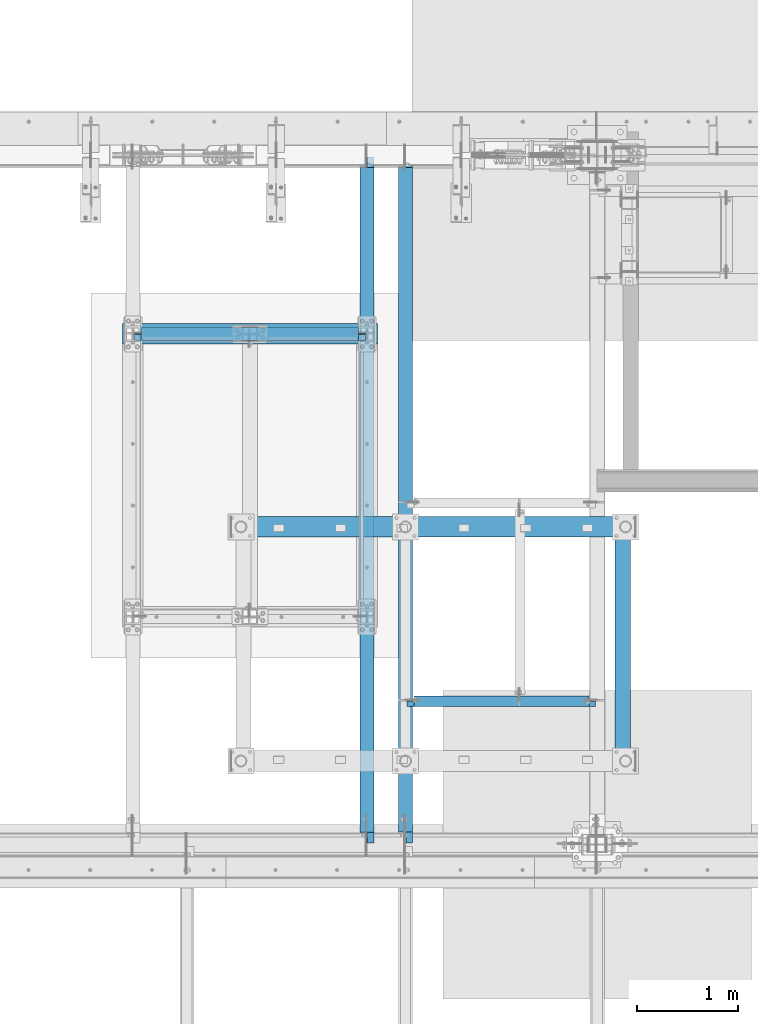
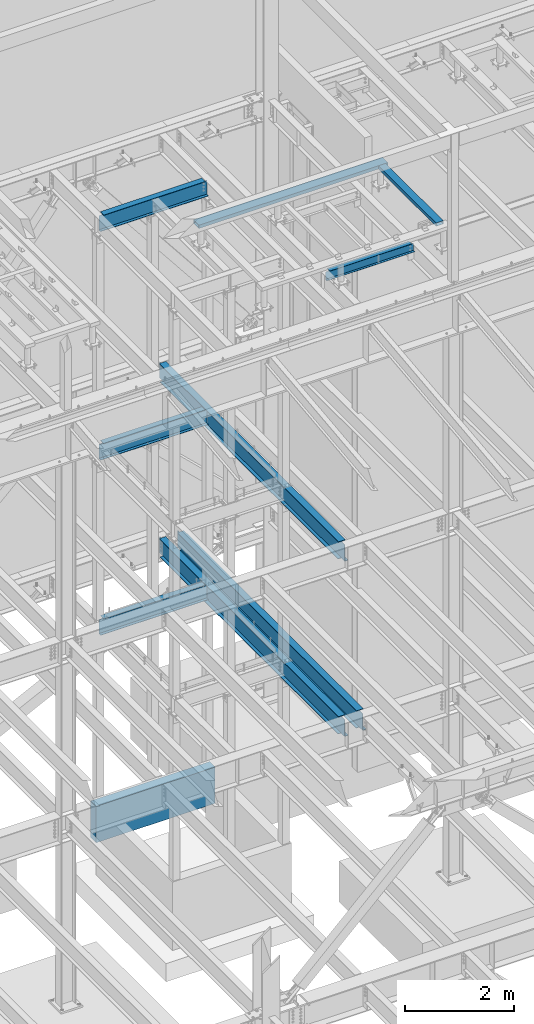
# One storey, part 773 of 1179: 10 beams, 9 elements without a shape of their own.
"""IFC2X3 building model written with IfcOpenShell, lengths in millimetres."""

from ifc_helpers import new_model, si_unit, frame, origin_with_axes, place, context, subcontext, project, spatial, faceted_brep, material, type_object, element, aggregate, save


model = new_model("IFC2X3")

# Units and contexts
model_context = context("Model", 3, precision=1e-05, world=origin_with_axes())
body_context = subcontext(model_context, "Body", "Model", "MODEL_VIEW")
ifc_project = project(units=[si_unit("LENGTHUNIT", "METRE", prefix="MILLI"), si_unit("AREAUNIT", "SQUARE_METRE"), si_unit("VOLUMEUNIT", "CUBIC_METRE"), si_unit("MASSUNIT", "GRAM", prefix="KILO"), si_unit("TIMEUNIT", "SECOND"), si_unit("PLANEANGLEUNIT", "RADIAN"), si_unit("SOLIDANGLEUNIT", "STERADIAN"), si_unit("THERMODYNAMICTEMPERATUREUNIT", "DEGREE_CELSIUS"), si_unit("LUMINOUSINTENSITYUNIT", "LUMEN")], contexts=[model_context])

# Site, building, storey
site_placement = place(None, origin_with_axes())
site = spatial("IfcSite", under=ifc_project, at=site_placement, CompositionType="ELEMENT")
building_placement = place(site_placement, origin_with_axes())
building = spatial("IfcBuilding", under=site, at=building_placement, Name="Undefined", CompositionType="ELEMENT")
storey_placement = place(building_placement, origin_with_axes())
storey = spatial("IfcBuildingStorey", under=building, at=storey_placement, Name="Undefined", CompositionType="ELEMENT", Elevation=0.0)

# Assembly, beam
assembly_1_placement = place(storey_placement, origin_with_axes())
assembly_1 = element("IfcElementAssembly", 1, at=assembly_1_placement, inside=storey, Name="BEAM", AssemblyPlace="NOTDEFINED", PredefinedType="RIGID_FRAME")
ifc_material_1 = material(Name="STEEL/A992")
beam_type_1 = type_object("IfcBeamType", Name="W14X22", PredefinedType="NOTDEFINED")
beam_1_placement = place(assembly_1_placement, frame((11874.5, 39433.5, 12944.475), z_axis=(0.0, 0.0, 1.0), x_axis=(1.0, 0.0, 0.0)))
beam_1 = element("IfcBeam", 2, at=beam_1_placement, type_object=beam_type_1, material=ifc_material_1, Name="BEAM", ObjectType="W14X22", context=body_context, shape_type="Brep", body=[
    faceted_brep([(69.8500001907341, -3.17500000000291, 142.874999999998), (69.8500001907341, 3.17497569180705, 142.874999999998), (15.8750000000018, 3.17500000000291, 142.874999999998), (15.8750000000018, -3.17500000000291, 142.874999999998), (74.7100797087805, -3.17500000000291, 143.841729922586), (74.7100797087805, 3.17497496696888, 143.841729922586), (78.8302561769342, -3.17500000000291, 146.594743823063), (78.8302561769342, 3.17497290281608, 146.594743823063), (81.5832700774117, -3.17500000000291, 150.714920291217), (81.5832700774117, 3.17496981359, 150.714920291217), (82.5499999999993, -3.17500000000291, 155.574999809263), (82.5499999999993, 3.17496616959397, 155.574999809263), (82.5499999999993, -63.5, 174.625), (82.5499999999993, 63.5, 174.625), (82.5499999999993, 63.5, 166.6875), (82.5499999999993, 3.17500000000291, 166.6875), (82.5499999999993, -3.17500000000291, 166.6875), (82.5499999999993, -63.5, 166.6875), (142.875000000002, 63.5, -166.6875), (142.875000000002, 3.17549991607666, -166.6875), (2168.52500000002, 3.17502949357731, -166.6875), (2168.52500000016, 63.5, -166.6875), (15.8750000000018, -3.17500000000291, -166.6875), (15.8750000000018, -63.5, -166.6875), (2295.525, -63.5, -166.6875), (2295.525, -3.17500000000291, -166.6875), (15.8750000000018, -63.5, -174.625), (2295.525, -63.5, -174.625), (2168.52500000016, 63.5, -174.625), (2168.525, 3.17549991607666, -174.625), (2295.525, 3.17549991607666, -174.625), (15.8750000000018, 3.17549991607666, -174.625), (142.875000000002, 3.17549991607666, -174.625), (142.875000000002, 63.5, -174.625), (15.8750000000018, 3.17500000000291, -166.6875), (2295.525, 3.17500000000291, -166.6875), (2295.525, 3.17500000000291, 142.874999999998), (2295.525, -3.17500000000291, 142.874999999998), (2241.54999980926, 3.17496469425532, 142.874999999998), (2241.54999980926, -3.17500000000291, 142.874999999998), (2236.68992029122, 3.17496396310162, 143.841729922586), (2236.68992029122, -3.17500000000291, 143.841729922586), (2232.56974382307, 3.17496188809309, 146.594743823063), (2232.56974382307, -3.17500000000291, 146.594743823063), (2229.81672992259, 3.17495878513728, 150.714920291217), (2229.81672992259, -3.17500000000291, 150.714920291217), (2228.85, 3.17495512662572, 155.574999809263), (2228.85, -3.17500000000291, 155.574999809263), (2228.85, -63.5, 174.625), (2228.85, -63.5, 166.6875), (2228.85, -3.17500000000291, 166.6875), (2228.85, 3.17500000000291, 166.6875), (2228.85, 63.5, 166.6875), (2228.85, 63.5, 174.625)], [[[0, 1, 2, 3]], [[4, 5, 1, 0]], [[6, 7, 5, 4]], [[8, 9, 7, 6]], [[10, 11, 9, 8]], [[12, 13, 14, 15, 11, 10, 16, 17]], [[18, 19, 20, 21]], [[22, 23, 24, 25]], [[23, 26, 27, 24]], [[28, 29, 30, 27, 26, 31, 32, 33]], [[19, 32, 31, 34]], [[18, 33, 32, 19]], [[33, 18, 21, 28]], [[20, 29, 28, 21]], [[35, 30, 29, 20]], [[25, 24, 27, 30, 35, 36, 37]], [[37, 36, 38, 39]], [[39, 38, 40, 41]], [[41, 40, 42, 43]], [[43, 42, 44, 45]], [[45, 44, 46, 47]], [[48, 49, 50, 47, 46, 51, 52, 53]], [[12, 17, 49, 48]], [[17, 16, 50, 49]], [[41, 43, 45, 47, 50, 16, 10, 8, 6, 4, 0, 3, 22, 25, 37, 39]], [[34, 31, 26, 23, 22, 3, 2]], [[35, 20, 19, 34, 2, 1, 5, 7, 9, 11, 15, 51, 46, 44, 42, 40, 38, 36]], [[15, 14, 52, 51]], [[14, 13, 53, 52]], [[13, 12, 48, 53]]]),
])
aggregate(assembly_1, [beam_1])

assembly_2_placement = place(storey_placement, origin_with_axes())
assembly_2 = element("IfcElementAssembly", 3, at=assembly_2_placement, inside=storey, Name="BEAM", AssemblyPlace="NOTDEFINED", PredefinedType="RIGID_FRAME")
beam_2_placement = place(assembly_2_placement, frame((11874.5, 39433.5, 7839.075), z_axis=(0.0, 0.0, 1.0), x_axis=(1.0, 0.0, 0.0)))
beam_2 = element("IfcBeam", 4, at=beam_2_placement, type_object=beam_type_1, material=ifc_material_1, Name="BEAM", ObjectType="W14X22", context=body_context, shape_type="Brep", body=[
    faceted_brep([(69.8500001907341, -3.17500000000291, 142.874999999998), (69.8500001907341, 3.17497569180705, 142.874999999998), (15.8750000000018, 3.17500000000291, 142.874999999998), (15.8750000000018, -3.17500000000291, 142.874999999998), (74.7100797087805, -3.17500000000291, 143.841729922586), (74.7100797087805, 3.17497496696888, 143.841729922586), (78.8302561769342, -3.17500000000291, 146.594743823063), (78.8302561769342, 3.17497290281608, 146.594743823063), (81.5832700774117, -3.17500000000291, 150.714920291217), (81.5832700774117, 3.17496981359, 150.714920291217), (82.5499999999993, -3.17500000000291, 155.574999809263), (82.5499999999993, 3.17496616959397, 155.574999809263), (82.5499999999993, -63.5, 174.625), (82.5499999999993, 63.5, 174.625), (82.5499999999993, 63.5, 166.6875), (82.5499999999993, 3.17500000000291, 166.6875), (82.5499999999993, -3.17500000000291, 166.6875), (82.5499999999993, -63.5, 166.6875), (142.875000000002, 63.5, -166.6875), (142.875000000002, 3.17549991607666, -166.6875), (2168.52500000002, 3.17502949357731, -166.6875), (2168.52500000016, 63.5, -166.6875), (15.8750000000018, -3.17500000000291, -166.6875), (15.8750000000018, -63.5, -166.6875), (2295.525, -63.5, -166.6875), (2295.525, -3.17500000000291, -166.6875), (15.8750000000018, -63.5, -174.625), (2295.525, -63.5, -174.625), (2168.52500000016, 63.5, -174.625), (2168.525, 3.17549991607666, -174.625), (2295.525, 3.17549991607666, -174.625), (15.8750000000018, 3.17549991607666, -174.625), (142.875000000002, 3.17549991607666, -174.625), (142.875000000002, 63.5, -174.625), (15.8750000000018, 3.17500000000291, -166.6875), (2295.525, 3.17500000000291, -166.6875), (2295.525, 3.17500000000291, 142.874999999998), (2295.525, -3.17500000000291, 142.874999999998), (2241.54999980926, 3.17496469425532, 142.874999999998), (2241.54999980926, -3.17500000000291, 142.874999999998), (2236.68992029122, 3.17496396310162, 143.841729922586), (2236.68992029122, -3.17500000000291, 143.841729922586), (2232.56974382307, 3.17496188809309, 146.594743823063), (2232.56974382307, -3.17500000000291, 146.594743823063), (2229.81672992259, 3.17495878513728, 150.714920291217), (2229.81672992259, -3.17500000000291, 150.714920291217), (2228.85, 3.17495512662572, 155.574999809263), (2228.85, -3.17500000000291, 155.574999809263), (2228.85, -63.5, 174.625), (2228.85, -63.5, 166.6875), (2228.85, -3.17500000000291, 166.6875), (2228.85, 3.17500000000291, 166.6875), (2228.85, 63.5, 166.6875), (2228.85, 63.5, 174.625)], [[[0, 1, 2, 3]], [[4, 5, 1, 0]], [[6, 7, 5, 4]], [[8, 9, 7, 6]], [[10, 11, 9, 8]], [[12, 13, 14, 15, 11, 10, 16, 17]], [[18, 19, 20, 21]], [[22, 23, 24, 25]], [[23, 26, 27, 24]], [[28, 29, 30, 27, 26, 31, 32, 33]], [[19, 32, 31, 34]], [[18, 33, 32, 19]], [[33, 18, 21, 28]], [[20, 29, 28, 21]], [[35, 30, 29, 20]], [[25, 24, 27, 30, 35, 36, 37]], [[37, 36, 38, 39]], [[39, 38, 40, 41]], [[41, 40, 42, 43]], [[43, 42, 44, 45]], [[45, 44, 46, 47]], [[48, 49, 50, 47, 46, 51, 52, 53]], [[12, 17, 49, 48]], [[17, 16, 50, 49]], [[41, 43, 45, 47, 50, 16, 10, 8, 6, 4, 0, 3, 22, 25, 37, 39]], [[34, 31, 26, 23, 22, 3, 2]], [[35, 20, 19, 34, 2, 1, 5, 7, 9, 11, 15, 51, 46, 44, 42, 40, 38, 36]], [[15, 14, 52, 51]], [[14, 13, 53, 52]], [[13, 12, 48, 53]]]),
])
aggregate(assembly_2, [beam_2])

assembly_3_placement = place(storey_placement, origin_with_axes())
assembly_3 = element("IfcElementAssembly", 5, at=assembly_3_placement, inside=storey, Name="BEAM", AssemblyPlace="NOTDEFINED", PredefinedType="RIGID_FRAME")
beam_3_placement = place(assembly_3_placement, frame((11874.5, 39433.5, 3927.475), z_axis=(0.0, 0.0, 1.0), x_axis=(1.0, 0.0, 0.0)))
beam_3 = element("IfcBeam", 6, at=beam_3_placement, type_object=beam_type_1, material=ifc_material_1, Name="BEAM", ObjectType="W14X22", context=body_context, shape_type="Brep", body=[
    faceted_brep([(69.8500001907341, -3.17500000000291, 142.874999999998), (69.8500001907341, 3.17497569180705, 142.874999999998), (15.8750000000018, 3.17500000000291, 142.874999999998), (15.8750000000018, -3.17500000000291, 142.874999999998), (74.7100797087805, -3.17500000000291, 143.841729922586), (74.7100797087805, 3.17497496696888, 143.841729922586), (78.8302561769342, -3.17500000000291, 146.594743823063), (78.8302561769342, 3.17497290281608, 146.594743823063), (81.5832700774117, -3.17500000000291, 150.714920291217), (81.5832700774117, 3.17496981359, 150.714920291217), (82.5499999999993, -3.17500000000291, 155.574999809263), (82.5499999999993, 3.17496616959397, 155.574999809263), (82.5499999999993, -63.5, 174.625), (82.5499999999993, 63.5, 174.625), (82.5499999999993, 63.5, 166.6875), (82.5499999999993, 3.17500000000291, 166.6875), (82.5499999999993, -3.17500000000291, 166.6875), (82.5499999999993, -63.5, 166.6875), (2168.52504248064, 3.17500000000291, -166.6875), (2168.52500000016, 63.5, -166.6875), (142.875000000002, 63.5, -166.6875), (142.875042480802, 3.17547110272426, -166.6875), (15.8750000000018, -3.17500000000291, -166.6875), (15.8750000000018, -63.5, -166.6875), (2295.525, -63.5, -166.6875), (2295.525, -3.17500000000291, -166.6875), (15.8750000000018, -63.5, -174.625), (2295.525, -63.5, -174.625), (2168.52500000016, 63.5, -174.625), (2168.52504248064, 3.17552491938841, -174.625), (2295.52504248177, 3.17552809441258, -174.625), (15.8750424817717, 3.17546792770008, -174.625), (142.875042480802, 3.17547110272426, -174.625), (142.875000000002, 63.5, -174.625), (15.8750000000018, 3.17500000000291, -166.6875), (2295.525, 3.17500000000291, -166.6875), (2295.525, 3.17500000000291, 142.874999999998), (2295.525, -3.17500000000291, 142.874999999998), (2241.55004395792, 3.17500000000291, 142.875), (2241.54999980926, -3.17500000000291, 142.874999999998), (2236.68996443988, 3.17500000000291, 143.841729922588), (2236.68992029122, -3.17500000000291, 143.841729922586), (2232.56978797172, 3.17500000000291, 146.594743823066), (2232.56974382307, -3.17500000000291, 146.594743823063), (2229.81677407125, 3.17500000000291, 150.71492029122), (2229.81672992259, -3.17500000000291, 150.714920291217), (2228.85004414866, 3.17500000000291, 155.574999809265), (2228.85, -3.17500000000291, 155.574999809263), (2228.85, -63.5, 174.625), (2228.85, -63.5, 166.6875), (2228.85, -3.17500000000291, 166.6875), (2228.85, 3.17500000000291, 166.6875), (2228.85, 63.5, 166.6875), (2228.85, 63.5, 174.625)], [[[0, 1, 2, 3]], [[4, 5, 1, 0]], [[6, 7, 5, 4]], [[8, 9, 7, 6]], [[10, 11, 9, 8]], [[12, 13, 14, 15, 11, 10, 16, 17]], [[18, 19, 20, 21]], [[22, 23, 24, 25]], [[23, 26, 27, 24]], [[28, 29, 30, 27, 26, 31, 32, 33]], [[21, 32, 31, 34]], [[20, 33, 32, 21]], [[33, 20, 19, 28]], [[18, 29, 28, 19]], [[35, 30, 29, 18]], [[25, 24, 27, 30, 35, 36, 37]], [[37, 36, 38, 39]], [[39, 38, 40, 41]], [[41, 40, 42, 43]], [[43, 42, 44, 45]], [[45, 44, 46, 47]], [[48, 49, 50, 47, 46, 51, 52, 53]], [[12, 17, 49, 48]], [[17, 16, 50, 49]], [[41, 43, 45, 47, 50, 16, 10, 8, 6, 4, 0, 3, 22, 25, 37, 39]], [[34, 31, 26, 23, 22, 3, 2]], [[51, 46, 44, 42, 40, 38, 36, 35, 18, 21, 34, 2, 1, 5, 7, 9, 11, 15]], [[15, 14, 52, 51]], [[14, 13, 53, 52]], [[13, 12, 48, 53]]]),
])
aggregate(assembly_3, [beam_3])

assembly_4_placement = place(storey_placement, origin_with_axes())
assembly_4 = element("IfcElementAssembly", 7, at=assembly_4_placement, inside=storey, Name="BEAM", AssemblyPlace="NOTDEFINED", PredefinedType="RIGID_FRAME")
beam_type_2 = type_object("IfcBeamType", Name="W16X31", PredefinedType="NOTDEFINED")
beam_4_placement = place(assembly_4_placement, frame((14185.9, 34391.6, 7812.0875), z_axis=(0.0, 0.0, 1.0), x_axis=(0.0, 1.0, 0.0)))
beam_4 = element("IfcBeam", 8, at=beam_4_placement, type_object=beam_type_2, material=ifc_material_1, Name="BEAM", ObjectType="W16X31", context=body_context, shape_type="Brep", body=[
    faceted_brep([(104.775000190733, -3.17499999999927, 166.6875), (104.775000190733, 3.17497120592088, 166.6875), (17.4624999999942, 3.17499999999927, 166.6875), (17.4624999999942, -3.17499999999927, 166.6875), (109.63507970878, -3.17499999999927, 167.654229922588), (109.63507970878, 3.17497058299341, 167.654229922588), (113.755256176933, -3.17499999999927, 170.407243823066), (113.755256176933, 3.17496880904946, 170.407243823066), (116.508270077407, -3.17499999999927, 174.52742029122), (116.508270077407, 3.17496615415439, 174.52742029122), (117.474999999999, -3.17499999999927, 179.387499809265), (117.474999999999, 3.17496302249128, 179.387499809265), (117.474999999999, -69.8499999999985, 201.6125), (117.474999999999, 69.8499999999985, 201.6125), (117.474999999999, 69.8499999999985, 190.5), (117.474999999999, 3.17499999999927, 190.5), (117.474999999999, -3.17499999999927, 190.5), (117.474999999999, -69.8499999999985, 190.5), (6660.35625, 3.17499999999927, -190.5), (6660.35625, 69.8500000000004, -190.5), (144.462499999994, 69.8499999999985, -190.5), (144.462499999994, 3.17549991607666, -190.5), (17.4624999999942, -3.17499999999927, -190.5), (17.4624999999942, -69.8499999999985, -190.5), (6787.35625, -69.8500000000004, -190.5), (6787.35625, -3.17499999999927, -190.5), (17.4624999999942, -69.8499999999985, -201.6125), (6787.35625, -69.8500000000004, -201.6125), (6660.35625, 69.8500000000004, -201.6125), (6660.35625, 3.17549991607484, -201.6125), (6787.35625, 3.17549991607484, -201.6125), (17.4624999999942, 3.17549991607666, -201.6125), (144.462499999994, 3.17549991607666, -201.6125), (144.462499999994, 69.8499999999985, -201.6125), (17.4624999999942, 3.17499999999927, -190.5), (6787.35625, 3.17499999999927, -190.5), (6787.35625, 3.17499999999927, 157.1625), (6787.35625, -3.17499999999927, 157.1625), (6700.04374980927, 3.17499999999927, 157.1625), (6700.04374980927, -3.17499999999927, 157.1625), (6695.18367029123, 3.17499999999927, 158.129229922588), (6695.18367029123, -3.17499999999927, 158.129229922588), (6691.06349382307, 3.17499999999927, 160.882243823066), (6691.06349382307, -3.17499999999927, 160.882243823066), (6688.31047992259, 3.17499999999927, 165.00242029122), (6688.31047992259, -3.17499999999927, 165.00242029122), (6687.34375000001, 3.17499999999927, 169.862499809266), (6687.34375000001, -3.17499999999927, 169.862499809266), (6687.34375000001, -69.8500000000004, 201.6125), (6687.34375000001, -69.8500000000004, 190.5), (6687.34375000001, -3.17499999999927, 190.5), (6687.34375000001, 3.17499999999927, 190.5), (6687.34375000001, 69.8500000000004, 190.5), (6687.34375000001, 69.8500000000004, 201.6125)], [[[0, 1, 2, 3]], [[4, 5, 1, 0]], [[6, 7, 5, 4]], [[8, 9, 7, 6]], [[10, 11, 9, 8]], [[12, 13, 14, 15, 11, 10, 16, 17]], [[18, 19, 20, 21]], [[22, 23, 24, 25]], [[23, 26, 27, 24]], [[28, 29, 30, 27, 26, 31, 32, 33]], [[21, 32, 31, 34]], [[20, 33, 32, 21]], [[19, 28, 33, 20]], [[18, 29, 28, 19]], [[35, 30, 29, 18]], [[25, 24, 27, 30, 35, 36, 37]], [[37, 36, 38, 39]], [[39, 38, 40, 41]], [[41, 40, 42, 43]], [[43, 42, 44, 45]], [[45, 44, 46, 47]], [[48, 49, 50, 47, 46, 51, 52, 53]], [[49, 48, 12, 17]], [[50, 49, 17, 16]], [[8, 6, 4, 0, 3, 22, 25, 37, 39, 41, 43, 45, 47, 50, 16, 10]], [[34, 31, 26, 23, 22, 3, 2]], [[51, 46, 44, 42, 40, 38, 36, 35, 18, 21, 34, 2, 1, 5, 7, 9, 11, 15]], [[52, 51, 15, 14]], [[53, 52, 14, 13]], [[48, 53, 13, 12]]]),
])
aggregate(assembly_4, [beam_4])

assembly_5_placement = place(storey_placement, origin_with_axes())
assembly_5 = element("IfcElementAssembly", 9, at=assembly_5_placement, inside=storey, Name="BEAM", AssemblyPlace="NOTDEFINED", PredefinedType="RIGID_FRAME")
beam_5_placement = place(assembly_5_placement, frame((14566.9001686096, 34391.6, 3900.4875), z_axis=(0.0, 0.0, 1.0), x_axis=(0.0, 1.0, 0.0)))
beam_5 = element("IfcBeam", 10, at=beam_5_placement, type_object=beam_type_2, material=ifc_material_1, Name="BEAM", ObjectType="W16X31", context=body_context, shape_type="Brep", body=[
    faceted_brep([(113.506251936145, -3.17499999997744, 169.8625), (113.506251936145, 3.17496422017757, 169.8625), (18.2562514952835, 3.17499999999927, 169.8625), (18.2562514952835, -3.17499999999927, 169.8625), (118.366331454192, -3.17499999997926, 170.829229922588), (118.366331454192, 3.17496349569046, 170.829229922588), (122.486507922345, -3.17499999997744, 173.582243823066), (122.486507922345, 3.17496143253265, 173.582243823066), (125.239521822827, -3.17499999997563, 177.70242029122), (125.239521822819, 3.17495834479632, 177.70242029122), (126.206251745411, -3.17499999997744, 182.562499809265), (126.206251745411, 3.1749547025629, 182.562499809265), (126.206251745432, -69.8499999999767, 201.6125), (126.206251745396, 69.850000000024, 201.6125), (126.206251745396, 69.850000000024, 190.5), (126.206251745418, 3.17500000002292, 190.5), (126.206251745411, -3.17499999997744, 190.5), (126.206251745432, -69.8499999999767, 190.5), (6660.35625, 3.17499999999927, -190.5), (6660.35625, 69.8500000000004, -190.5), (145.256250000001, 69.8499999999985, -190.5), (145.256250079394, 3.17558137532069, -190.5), (18.2562500000006, -3.17500000000291, -190.5), (18.2562500000006, -69.8499999999985, -190.5), (6787.35625, -69.8500000000004, -190.5), (6787.35625, -3.17499999999927, -190.5), (18.2562500000006, -69.8499999999985, -201.612499999999), (6787.35625, -69.8500000000004, -201.6125), (6660.35625, 69.8500000000004, -201.6125), (6660.35625, 3.1754070527486, -201.6125), (6787.35625, 3.1754070527486, -201.6125), (18.2562500793938, 3.17558455032122, -201.6125), (145.256250079394, 3.17558137532069, -201.6125), (145.256250000001, 69.8499999999985, -201.612499999999), (18.2562500000006, 3.17500000000291, -190.5), (6787.35625, 3.17499999999927, -190.5), (6787.35625007939, 3.17500000129257, 163.512499999999), (6787.35624992065, -3.17499999870779, 163.512499999999), (6700.04375155555, 3.1750000012762, 163.512499999999), (6700.04375155555, -3.17499999872416, 163.512499999999), (6695.18367203751, 3.1750000012762, 164.479229922587), (6695.18367203751, -3.17499999872416, 164.479229922587), (6691.06349556935, 3.17500000127438, 167.232243823065), (6691.06349556935, -3.17499999872598, 167.232243823065), (6688.31048166887, 3.17500000127438, 171.352420291219), (6688.31048166887, -3.17499999872598, 171.352420291219), (6687.34375174628, 3.17500000127438, 176.212499809265), (6687.34375174629, -3.17499999872598, 176.212499809265), (6687.34375000001, -69.8500000000004, 201.6125), (6687.34375000001, -69.8500000000004, 190.5), (6687.34375000001, -3.17499999999927, 190.5), (6687.34375000001, 3.17499999999927, 190.5), (6687.34375000001, 69.8500000000004, 190.5), (6687.34375000001, 69.8500000000004, 201.6125)], [[[0, 1, 2, 3]], [[4, 5, 1, 0]], [[6, 7, 5, 4]], [[8, 9, 7, 6]], [[10, 11, 9, 8]], [[12, 13, 14, 15, 11, 10, 16, 17]], [[18, 19, 20, 21]], [[22, 23, 24, 25]], [[23, 26, 27, 24]], [[28, 29, 30, 27, 26, 31, 32, 33]], [[21, 32, 31, 34]], [[20, 33, 32, 21]], [[19, 28, 33, 20]], [[18, 29, 28, 19]], [[35, 30, 29, 18]], [[25, 24, 27, 30, 35, 36, 37]], [[37, 36, 38, 39]], [[39, 38, 40, 41]], [[41, 40, 42, 43]], [[43, 42, 44, 45]], [[45, 44, 46, 47]], [[48, 49, 50, 47, 46, 51, 52, 53]], [[49, 48, 12, 17]], [[50, 49, 17, 16]], [[8, 6, 4, 0, 3, 22, 25, 37, 39, 41, 43, 45, 47, 50, 16, 10]], [[34, 31, 26, 23, 22, 3, 2]], [[51, 46, 44, 42, 40, 38, 36, 35, 18, 21, 34, 2, 1, 5, 7, 9, 11, 15]], [[52, 51, 15, 14]], [[53, 52, 14, 13]], [[48, 53, 13, 12]]]),
])
aggregate(assembly_5, [beam_5])

assembly_6_placement = place(storey_placement, origin_with_axes())
assembly_6 = element("IfcElementAssembly", 11, at=assembly_6_placement, inside=storey, Name="BEAM", AssemblyPlace="NOTDEFINED", PredefinedType="RIGID_FRAME")
beam_6_placement = place(assembly_6_placement, frame((14185.9001686096, 34391.6, 3900.4875), z_axis=(0.0, 0.0, 1.0), x_axis=(0.0, 1.0, 0.0)))
beam_6 = element("IfcBeam", 12, at=beam_6_placement, type_object=beam_type_2, material=ifc_material_1, Name="BEAM", ObjectType="W16X31", context=body_context, shape_type="Brep", body=[
    faceted_brep([(18.2562500000006, -69.8499999999985, -190.5), (18.2562500000006, -69.8499999999985, -201.612499999999), (6787.35625, -69.8500000000004, -201.6125), (6787.35625, -69.8500000000004, -190.5), (18.2562500793938, 3.17558455032122, -201.6125), (145.256250079394, 3.17558137532069, -201.6125), (145.256250000001, 69.8499999999985, -201.612499999999), (6660.35625, 69.8500000000004, -201.6125), (6660.3562500794, 3.17555155085756, -201.6125), (6787.35625, 3.17549991607484, -201.6125), (145.256250079394, 3.17558137532069, -190.5), (18.2562500000006, 3.17500000000291, -190.5), (145.256250000001, 69.8499999999985, -190.5), (6660.35625, 3.17499999999927, -190.5), (6660.35625, 69.8500000000004, -190.5), (6787.35625, 3.17499999999927, -190.5), (6787.35625, -3.17499999999927, -190.5), (6787.35625007939, 3.17500000129257, 163.512499999999), (6787.35624992065, -3.17499999870779, 163.512499999999), (18.2562500000006, -3.17500000000291, -190.5), (18.2562514952835, -3.17499999999927, 169.8625), (18.2562514952835, 3.17499999999927, 169.8625), (113.506251936145, -3.17499999997744, 169.8625), (113.506251936145, 3.17496422017757, 169.8625), (118.366331454192, -3.17499999997926, 170.829229922588), (118.366331454192, 3.17496349569046, 170.829229922588), (122.486507922345, -3.17499999997744, 173.582243823066), (122.486507922345, 3.17496143253265, 173.582243823066), (125.239521822827, -3.17499999997563, 177.70242029122), (125.239521822819, 3.17495834479632, 177.70242029122), (126.206251745411, -3.17499999997744, 182.562499809265), (126.206251745411, 3.1749547025629, 182.562499809265), (126.206251745432, -69.8499999999767, 201.6125), (126.206251745396, 69.850000000024, 201.6125), (126.206251745396, 69.850000000024, 190.5), (126.206251745418, 3.17500000002292, 190.5), (126.206251745411, -3.17499999997744, 190.5), (126.206251745432, -69.8499999999767, 190.5), (6687.34375000001, 69.8500000000004, 190.5), (6687.34375000001, 3.17499999999927, 190.5), (6687.3437517463, 3.17494718995658, 176.212499809265), (6688.31048166887, 3.17500000127438, 171.352420291219), (6691.06349556935, 3.17500000127438, 167.232243823065), (6695.18367203751, 3.1750000012762, 164.479229922587), (6700.04375155555, 3.1750000012762, 163.512499999999), (6688.31048166887, -3.17499999872598, 171.352420291219), (6687.34375174629, -3.17499999872598, 176.212499809265), (6691.06349556935, -3.17499999872598, 167.232243823065), (6695.18367203751, -3.17499999872416, 164.479229922587), (6700.04375155555, -3.17499999872416, 163.512499999999), (6687.34375000001, -3.17499999999927, 190.5), (6687.34375000001, -69.8500000000004, 190.5), (6687.34375000001, -69.8500000000004, 201.6125), (6687.34375000001, 69.8500000000004, 201.6125)], [[[0, 1, 2, 3]], [[2, 1, 4, 5, 6, 7, 8, 9]], [[10, 5, 4, 11]], [[12, 6, 5, 10]], [[13, 14, 12, 10]], [[14, 7, 6, 12]], [[13, 8, 7, 14]], [[15, 9, 8, 13]], [[16, 3, 2, 9, 15, 17, 18]], [[19, 0, 3, 16]], [[11, 4, 1, 0, 19, 20, 21]], [[22, 23, 21, 20]], [[24, 25, 23, 22]], [[26, 27, 25, 24]], [[28, 29, 27, 26]], [[30, 31, 29, 28]], [[32, 33, 34, 35, 31, 30, 36, 37]], [[38, 39, 35, 34]], [[15, 13, 10, 11, 21, 23, 25, 27, 29, 31, 35, 39, 40, 41, 42, 43, 44, 17]], [[45, 41, 40, 46]], [[47, 42, 41, 45]], [[48, 43, 42, 47]], [[49, 44, 43, 48]], [[18, 17, 44, 49]], [[28, 26, 24, 22, 20, 19, 16, 18, 49, 48, 47, 45, 46, 50, 36, 30]], [[50, 51, 37, 36]], [[51, 52, 32, 37]], [[52, 53, 33, 32]], [[53, 38, 34, 33]], [[52, 51, 50, 46, 40, 39, 38, 53]]]),
])
aggregate(assembly_6, [beam_6])

# Assembly, beams
assembly_7_placement = place(storey_placement, origin_with_axes())
assembly_7 = element("IfcElementAssembly", 13, at=assembly_7_placement, inside=storey, Name="FRAME", AssemblyPlace="NOTDEFINED", PredefinedType="RIGID_FRAME")
ifc_material_2 = material()
beam_type_3 = type_object("IfcBeamType", Name="HSS6X3X1/4", PredefinedType="NOTDEFINED")
beam_7_placement = place(assembly_7_placement, frame((16713.2, 35318.7, 13722.35), z_axis=(1.0, 0.0, 0.0), x_axis=(0.0, 1.0, 0.0)))
beam_7 = element("IfcBeam", 14, at=beam_7_placement, type_object=beam_type_3, material=ifc_material_2, Name="BEAM", ObjectType="HSS6X3X1/4", context=body_context, shape_type="Brep", body=[
    faceted_brep([(0.0, 31.75, -69.8499999999985), (0.0, -31.75, -69.8499999999985), (2108.2, -31.75, -69.8499999999985), (2108.2, 31.75, -69.8499999999985), (0.0, -31.75, 69.8499999999985), (2108.2, -31.75, 69.8499999999985), (0.0, 31.75, 69.8499999999985), (2108.2, 31.75, 69.8499999999985), (0.0, 38.0999999999985, -76.1999999999998), (0.0, 38.0999999999985, 76.1999999999998), (2108.2, 38.1000000000004, 76.2000000000007), (2108.2, 38.1000000000004, -76.2000000000007), (0.0, -38.0999999999985, 76.1999999999998), (2108.2, -38.1000000000004, 76.2000000000007), (0.0, -38.0999999999985, -76.1999999999998), (2108.2, -38.1000000000004, -76.2000000000007)], [[[0, 1, 2, 3]], [[1, 4, 5, 2]], [[4, 6, 7, 5]], [[6, 0, 3, 7]], [[8, 9, 10, 11]], [[9, 12, 13, 10]], [[12, 14, 15, 13]], [[14, 8, 11, 15]], [[13, 15, 11, 10], [5, 7, 3, 2]], [[14, 12, 9, 8], [6, 4, 1, 0]]]),
])
beam_type_4 = type_object("IfcBeamType", Name="HSS8X3X1/4", PredefinedType="NOTDEFINED")
beam_8_placement = place(assembly_7_placement, frame((12839.7, 37528.5, 13722.35), z_axis=(0.0, -1.0, 0.0), x_axis=(1.0, 0.0, 0.0)))
beam_8 = element("IfcBeam", 15, at=beam_8_placement, type_object=beam_type_4, material=ifc_material_2, Name="FRAME", ObjectType="HSS8X3X1/4", context=body_context, shape_type="Brep", body=[
    faceted_brep([(4.76249999999709, 31.75, -95.25), (4.76249999999709, -31.75, -95.25), (3995.7375, -31.75, -95.25), (3995.7375, 31.75, -95.25), (4.76249999999709, -31.75, 95.25), (3995.7375, -31.75, 95.25), (4.76249999999709, 31.75, 95.25), (3995.7375, 31.75, 95.25), (4.76249999999709, 38.1000000000004, -101.599999999999), (4.76249999999709, 38.1000000000004, 101.599999999999), (3995.7375, 38.1000000000004, 101.599999999999), (3995.7375, 38.1000000000004, -101.599999999999), (4.76249999999709, -38.1000000000004, 101.599999999999), (3995.7375, -38.1000000000004, 101.599999999999), (4.76249999999709, -38.1000000000004, -101.599999999999), (3995.7375, -38.1000000000004, -101.599999999999)], [[[0, 1, 2, 3]], [[1, 4, 5, 2]], [[4, 6, 7, 5]], [[6, 0, 3, 7]], [[8, 9, 10, 11]], [[9, 12, 13, 10]], [[12, 14, 15, 13]], [[14, 8, 11, 15]], [[13, 15, 11, 10], [5, 7, 3, 2]], [[14, 12, 9, 8], [6, 4, 1, 0]]]),
])
aggregate(assembly_7, [beam_7, beam_8])

# Assembly, beam
assembly_8_placement = place(storey_placement, origin_with_axes())
assembly_8 = element("IfcElementAssembly", 16, at=assembly_8_placement, inside=storey, Name="BEAM", AssemblyPlace="NOTDEFINED", PredefinedType="RIGID_FRAME")
beam_type_5 = type_object("IfcBeamType", Name="W8X10", PredefinedType="NOTDEFINED")
beam_9_placement = place(assembly_8_placement, frame((14566.9, 35807.65, 13019.0875), z_axis=(0.0, 0.0, 1.0), x_axis=(1.0, 0.0, 0.0)))
beam_9 = element("IfcBeam", 17, at=beam_9_placement, type_object=beam_type_5, material=ifc_material_1, Name="BEAM", ObjectType="W8X10", context=body_context, shape_type="Brep", body=[
    faceted_brep([(1809.75, -50.8000000000029, 100.012500000001), (1809.75, -50.8000000000029, 95.25), (1809.75, -2.38124999999854, 95.25), (1809.75, -2.38124999999854, 80.962499809264), (1809.75, 2.38121389596199, 80.962499809264), (1809.75, 2.38124999999854, 95.25), (1809.75, 50.8000000000029, 95.25), (1809.75, 50.8000000000029, 100.012500000001), (1810.71672992259, -2.38124999999854, 76.1024202912176), (1810.71672992259, 2.38122031080275, 76.1024202912176), (1813.46974382307, -2.38124999999854, 71.982243823064), (1813.46974382307, 2.38122575113084, 71.982243823064), (1817.58992029122, -2.38124999999854, 69.2292299225865), (1817.58992029122, 2.3812293887022, 69.2292299225865), (1822.44999980927, -2.38124999999854, 68.2624999999989), (1822.44999980927, 2.38123066972184, 68.2624999999989), (1876.425, -2.38124999999854, 68.2624999999989), (1876.425, 2.38124999999854, 68.2624999999989), (82.5499999999975, -50.8000000000029, 100.012500000001), (82.5499999999975, 50.8000000000029, 100.012500000001), (82.5499999999975, 50.8000000000029, 95.25), (82.5499999999975, 2.38124999999854, 95.25), (82.5499999999975, 2.3812255131852, 80.962499809264), (82.5499999999975, -2.38124999999854, 80.962499809264), (82.5499999999975, -2.38124999999854, 95.25), (82.5499999999975, -50.8000000000029, 95.25), (81.5832700774099, 2.38123189017642, 76.1024202912176), (81.5832700774099, -2.38124999999854, 76.1024202912176), (78.8302561769324, 2.38123729632207, 71.982243823064), (78.8302561769324, -2.38124999999854, 71.982243823064), (74.7100797087787, 2.38124090859492, 69.2292299225865), (74.7100797087787, -2.38124999999854, 69.2292299225865), (69.8500001907323, 2.38124217705627, 68.2624999999989), (69.8500001907323, -2.38124999999854, 68.2624999999989), (15.875, 2.38124999999854, 68.2624999999989), (15.875, -2.38124999999854, 68.2624999999989), (15.875, 2.38124999999854, -95.25), (15.875, 2.38174991607957, -100.012500000001), (15.875, -50.8000000000029, -100.012500000001), (15.875, -50.8000000000029, -95.25), (15.875, -2.38124999999854, -95.25), (142.875, 2.38174991607957, -95.25), (142.875, 2.38174991607957, -100.012500000001), (142.875, 50.8000000000029, -95.25), (142.875, 50.8000000000029, -100.012500000001), (1749.42499999983, 2.38128662388772, -95.25), (1749.425, 50.8000000000029, -95.25), (1749.425, 50.8000000000029, -100.012500000001), (1749.425, 2.38174991607957, -100.012500000001), (1876.425, 2.38124999999854, -95.25), (1876.425, 2.38174991607957, -100.012500000001), (1876.425, -50.8000000000029, -100.012500000001), (1876.425, -50.8000000000029, -95.25), (1876.425, -2.38124999999854, -95.25)], [[[0, 1, 2, 3, 4, 5, 6, 7]], [[8, 9, 4, 3]], [[10, 11, 9, 8]], [[12, 13, 11, 10]], [[14, 15, 13, 12]], [[16, 17, 15, 14]], [[18, 19, 20, 21, 22, 23, 24, 25]], [[23, 22, 26, 27]], [[27, 26, 28, 29]], [[29, 28, 30, 31]], [[31, 30, 32, 33]], [[33, 32, 34, 35]], [[36, 37, 38, 39, 40, 35, 34]], [[41, 42, 37, 36]], [[43, 44, 42, 41]], [[43, 41, 45, 46]], [[44, 43, 46, 47]], [[45, 48, 47, 46]], [[49, 50, 48, 45]], [[51, 38, 37, 42, 44, 47, 48, 50]], [[39, 38, 51, 52]], [[40, 39, 52, 53]], [[12, 10, 8, 3, 2, 24, 23, 27, 29, 31, 33, 35, 40, 53, 16, 14]], [[25, 24, 2, 1]], [[18, 25, 1, 0]], [[19, 18, 0, 7]], [[20, 19, 7, 6]], [[21, 20, 6, 5]], [[49, 45, 41, 36, 34, 32, 30, 28, 26, 22, 21, 5, 4, 9, 11, 13, 15, 17]], [[53, 52, 51, 50, 49, 17, 16]]]),
])
aggregate(assembly_8, [beam_9])

assembly_9_placement = place(storey_placement, origin_with_axes())
assembly_9 = element("IfcElementAssembly", 18, at=assembly_9_placement, inside=storey, Name="BEAM", AssemblyPlace="NOTDEFINED", PredefinedType="REINFORCEMENT_UNIT")
ifc_material_3 = material(Name="CONCRETE/5000")
beam_type_6 = type_object("IfcBeamType", PredefinedType="NOTDEFINED")
beam_10_placement = place(assembly_9_placement, frame((11772.9, 39433.5, -406.4), z_axis=(0.0, 0.0, 1.0), x_axis=(1.0, 0.0, 0.0)))
beam_10 = element("IfcBeam", 19, at=beam_10_placement, type_object=beam_type_6, material=ifc_material_3, Name="BEAM", context=body_context, shape_type="Brep", body=[
    faceted_brep([(-4.36557456851006e-11, 101.6, -406.4), (-4.36557456851006e-11, 101.6, 406.4), (2514.59990234375, 101.599999999999, 406.4), (2514.59990234375, 101.599999999999, -406.4), (4.36557456851006e-11, -101.6, 406.4), (2514.59990234375, -101.599999999999, 406.4), (4.36557456851006e-11, -101.6, -406.4), (2514.59990234375, -101.599999999999, -406.4)], [[[0, 1, 2, 3]], [[1, 4, 5, 2]], [[4, 6, 7, 5]], [[6, 0, 3, 7]], [[5, 7, 3, 2]], [[6, 4, 1, 0]]]),
])
aggregate(assembly_9, [beam_10])

save(model, "model.ifc")
